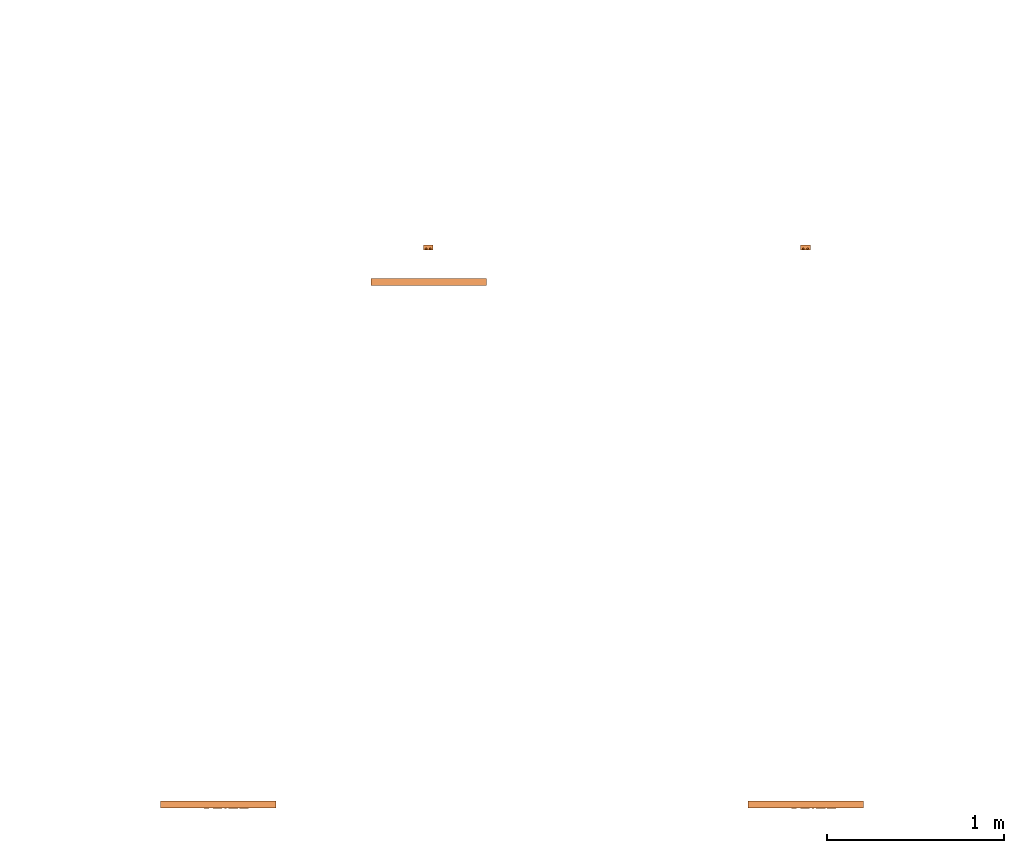
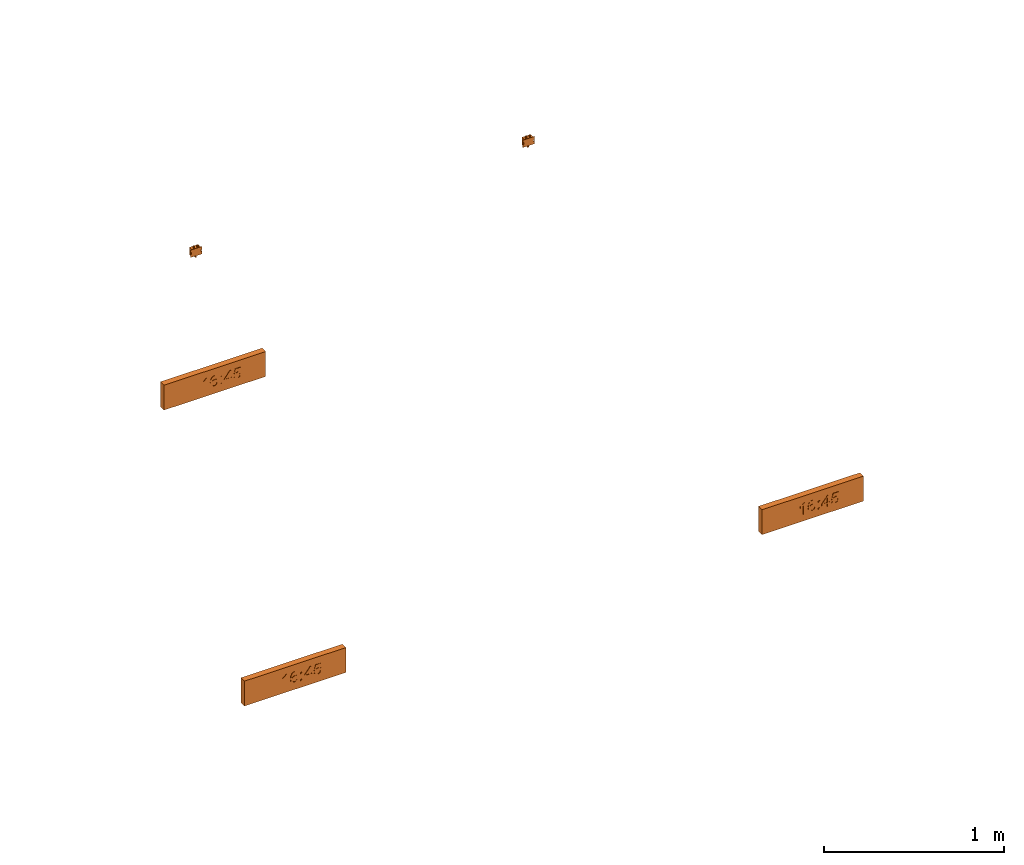
# One storey, part 4 of 6: 5 proxies.
"""IFC2X3 building model written with IfcOpenShell, lengths in millimetres."""

import ifcopenshell
import ifcopenshell.guid

model = None  # the IFC model being written
_history = None  # IfcOwnerHistory: only IFC2X3 demands one
_inside = {}  # id of a spatial element -> (the spatial element, [elements in it])
_under = {}  # id of a project, library or spatial element -> (it, [spatial elements below it])
_declared = {}  # id of a project -> (the project, [libraries it declares])
_typed = {}  # id of a type object -> (the type object, [elements of that type])
_made_of = {}  # id of a material, layer set ... -> (it, [elements and type objects made of it])


def new_model(schema):
    """Start an empty IFC model of exactly this schema.

    Asked for "IFC4X3", IfcOpenShell would pick the latest addendum, in which some entities
    have other attributes; the version numbers below select the first issue.
    IFC2X3 requires an IfcOwnerHistory on every rooted entity: one is made here for all.
    """
    global model, _history
    if schema == "IFC4X3":
        model = ifcopenshell.file(schema_version=(4, 3, 0, 0))
    else:
        model = ifcopenshell.file(schema=schema)
    _inside.clear()
    _under.clear()
    _declared.clear()
    _typed.clear()
    _made_of.clear()
    _history = None
    if model.schema == "IFC2X3":
        org = make("IfcOrganization", Name="unknown")
        user = make(
            "IfcPersonAndOrganization",
            ThePerson=make("IfcPerson", FamilyName="unknown"),
            TheOrganization=org,
        )
        app = make(
            "IfcApplication",
            ApplicationDeveloper=org,
            Version="unknown",
            ApplicationFullName="unknown",
            ApplicationIdentifier="unknown",
        )
        _history = make(
            "IfcOwnerHistory",
            OwningUser=user,
            OwningApplication=app,
            ChangeAction="ADDED",
            CreationDate=0,
        )
    return model


def make(cls, **values):
    """One entity of the class cls with the attributes given. An attribute that is None is left unset."""
    return model.create_entity(
        cls, **{name: value for name, value in values.items() if value is not None}
    )


def entity(cls, *values):
    """Any entity or typed value of the class cls, its attributes in the order of the schema. None: left unset."""
    e = model.create_entity(cls)
    for i, value in enumerate(values):
        if value is not None:
            e[i] = value
    return e


def rooted(cls, **values):
    """An entity with a GlobalId (a new one), such as an element, a storey or a relation."""
    return make(cls, GlobalId=ifcopenshell.guid.new(), OwnerHistory=_history, **values)


def si_unit(unit_type, name, prefix=None):
    """IfcSIUnit, for example si_unit("LENGTHUNIT", "METRE", prefix="MILLI")."""
    return make("IfcSIUnit", UnitType=unit_type, Prefix=prefix, Name=name)


def converted_unit(unit_type, name, factor, base, dimensions=None, offset=None):
    """IfcConversionBasedUnit, such as the inch: factor (a typed value) times the base unit."""
    return make(
        "IfcConversionBasedUnit"
        if offset is None
        else "IfcConversionBasedUnitWithOffset",
        ConversionOffset=offset,
        Dimensions=None
        if dimensions is None
        else entity("IfcDimensionalExponents", *dimensions),
        UnitType=unit_type,
        Name=name,
        ConversionFactor=make(
            "IfcMeasureWithUnit", ValueComponent=factor, UnitComponent=base
        ),
    )


def derived_unit(unit_type, elements):
    """IfcDerivedUnit: a product of units, each with its exponent."""
    return make(
        "IfcDerivedUnit",
        Elements=[
            make("IfcDerivedUnitElement", Unit=unit, Exponent=power)
            for unit, power in elements
        ],
        UnitType=unit_type,
    )


def assignment(units):
    """IfcUnitAssignment: the units of a project."""
    return None if units is None else make("IfcUnitAssignment", Units=units)


def point(xyz):
    """IfcCartesianPoint."""
    return None if xyz is None else make("IfcCartesianPoint", Coordinates=xyz)


def direction(xyz):
    """IfcDirection."""
    return None if xyz is None else make("IfcDirection", DirectionRatios=xyz)


def frame(location, z_axis=None, x_axis=None):
    """IfcAxis2Placement3D, a coordinate frame: its origin and axes. An axis left out is left unset."""
    return make(
        "IfcAxis2Placement3D",
        Location=point(location),
        Axis=direction(z_axis),
        RefDirection=direction(x_axis),
    )


def frame_2d(location, x_axis=None):
    """IfcAxis2Placement2D, a coordinate frame in the plane: its origin and x axis."""
    return make(
        "IfcAxis2Placement2D", Location=point(location), RefDirection=direction(x_axis)
    )


def origin():
    """The frame at (0, 0, 0) with its axes left unset."""
    return frame((0.0, 0.0, 0.0))


def origin_2d_with_axis():
    """The frame at (0, 0) in the plane with the x axis (1, 0) written out."""
    return frame_2d((0.0, 0.0), x_axis=(1.0, 0.0))


def place(relative_to, where):
    """IfcLocalPlacement: puts the frame where relative to a parent placement (None: the world)."""
    return make(
        "IfcLocalPlacement", PlacementRelTo=relative_to, RelativePlacement=where
    )


def context(
    kind, dimensions, precision=None, world=None, true_north=None, identifier=None
):
    """IfcGeometricRepresentationContext, for example the 3D "Model" context."""
    return make(
        "IfcGeometricRepresentationContext",
        ContextIdentifier=identifier,
        ContextType=kind,
        CoordinateSpaceDimension=dimensions,
        Precision=precision,
        WorldCoordinateSystem=world,
        TrueNorth=true_north,
    )


def subcontext(parent, identifier, kind, view, scale=None):
    """IfcGeometricRepresentationSubContext, for example "Body" below "Model"."""
    return make(
        "IfcGeometricRepresentationSubContext",
        ContextIdentifier=identifier,
        ContextType=kind,
        ParentContext=parent,
        TargetScale=scale,
        TargetView=view,
    )


def project(units=None, contexts=None):
    """IfcProject with its units and contexts."""
    return rooted(
        "IfcProject",
        Name="project",
        RepresentationContexts=contexts,
        UnitsInContext=assignment(units),
    )


def spatial(cls, under=None, at=None, **own):
    """A site, building, storey or space (cls), placed at a placement, below another one or the project."""
    s = rooted(cls, ObjectPlacement=at, **own)
    if under is not None:
        _under.setdefault(under.id(), (under, []))[1].append(s)
    return s


def polyline(points):
    """IfcPolyline through the points."""
    return make("IfcPolyline", Points=[point(p) for p in points])


def circle_curve(where, radius):
    """IfcCircle in the frame where."""
    return make("IfcCircle", Position=where, Radius=radius)


def parameter(value):
    """IfcParameterValue: where a trimmed curve begins or ends, as a parameter of its basis curve."""
    return model.create_entity("IfcParameterValue", value)


def trimmed(basis, trim1, trim2, sense, master):
    """IfcTrimmedCurve: the piece of a basis curve between two trims."""
    return make(
        "IfcTrimmedCurve",
        BasisCurve=basis,
        Trim1=trim1,
        Trim2=trim2,
        SenseAgreement=sense,
        MasterRepresentation=master,
    )


def segment(curve, same_sense, transition):
    """IfcCompositeCurveSegment."""
    return make(
        "IfcCompositeCurveSegment",
        Transition=transition,
        SameSense=same_sense,
        ParentCurve=curve,
    )


def composite_curve(segments, self_intersect=None):
    """IfcCompositeCurve: segments joined end to end."""
    return make("IfcCompositeCurve", Segments=segments, SelfIntersect=self_intersect)


def profile(cls, at=None, kind="AREA", **sizes):
    """A parametric profile (cls). Its sizes go by their IFC names, for example OverallWidth=200.0."""
    return make(cls, ProfileType=kind, Position=at, **sizes)


def rectangle(**sizes):
    """IfcRectangleProfileDef."""
    return profile("IfcRectangleProfileDef", **sizes)


def circle(**sizes):
    """IfcCircleProfileDef."""
    return profile("IfcCircleProfileDef", **sizes)


def outline(outer, holes=None, kind="AREA"):
    """IfcArbitraryClosedProfileDef: a profile drawn as a closed curve; with holes, ...WithVoids."""
    if holes is None:
        return make("IfcArbitraryClosedProfileDef", ProfileType=kind, OuterCurve=outer)
    return make(
        "IfcArbitraryProfileDefWithVoids",
        ProfileType=kind,
        OuterCurve=outer,
        InnerCurves=holes,
    )


def extrude(swept, where, along, depth):
    """IfcExtrudedAreaSolid: the profile swept, set in the frame where, extruded along a direction by depth."""
    return make(
        "IfcExtrudedAreaSolid",
        SweptArea=swept,
        Position=where,
        ExtrudedDirection=direction(along),
        Depth=depth,
    )


def shape(context_of_items, identifier, shape_type, items):
    """IfcShapeRepresentation: the items that make up one representation, for example the "Body"."""
    return make(
        "IfcShapeRepresentation",
        ContextOfItems=context_of_items,
        RepresentationIdentifier=identifier,
        RepresentationType=shape_type,
        Items=items,
    )


def source(mapping_origin, context_of_items, identifier, shape_type, items):
    """IfcRepresentationMap: a shape defined once, which mapped items show again and again."""
    return make(
        "IfcRepresentationMap",
        MappingOrigin=mapping_origin,
        MappedRepresentation=shape(context_of_items, identifier, shape_type, items),
    )


def transform(
    local_origin,
    x_axis=None,
    y_axis=None,
    z_axis=None,
    scale=None,
    scale2=None,
    scale3=None,
    uniform=True,
):
    """IfcCartesianTransformationOperator3D, or its non-uniform kind. x_axis, y_axis, z_axis: its Axis1, 2, 3."""
    if uniform:
        return make(
            "IfcCartesianTransformationOperator3D",
            Axis1=direction(x_axis),
            Axis2=direction(y_axis),
            LocalOrigin=point(local_origin),
            Scale=scale,
            Axis3=direction(z_axis),
        )
    return make(
        "IfcCartesianTransformationOperator3DnonUniform",
        Axis1=direction(x_axis),
        Axis2=direction(y_axis),
        LocalOrigin=point(local_origin),
        Scale=scale,
        Axis3=direction(z_axis),
        Scale2=scale2,
        Scale3=scale3,
    )


def mapped(mapping_source, mapping_target):
    """IfcMappedItem: shows the shape of a source again, moved by a transform."""
    return make(
        "IfcMappedItem", MappingSource=mapping_source, MappingTarget=mapping_target
    )


def material(Name=None, Category=None):
    """IfcMaterial."""
    return make("IfcMaterial", Name=Name, Category=Category)


def material_list(materials):
    """IfcMaterialList."""
    return make("IfcMaterialList", Materials=materials)


def made_of(thing, what):
    """Note that an element or type object is made of a material, layer set ...; save() writes the relation."""
    if what is not None:
        _made_of.setdefault(what.id(), (what, []))[1].append(thing)
    return thing


def type_object(cls, material=None, **own):
    """A type object (cls), such as IfcWallType, which elements share."""
    return made_of(rooted(cls, **own), material)


def type_shapes(of_type, sources):
    """Give a type object the sources (RepresentationMaps) that its elements show as mapped items."""
    of_type.RepresentationMaps = sources


def element(
    cls,
    number,
    at=None,
    inside=None,
    cuts=None,
    type_object=None,
    material=None,
    context=None,
    identifier="Body",
    shape_type=None,
    held_by="IfcProductDefinitionShape",
    body=None,
    shapes=None,
    **own,
):
    """One element of the class cls, such as IfcWall. Its Tag is "e" and its number.

    at: its placement. inside: the storey or other place that contains it. cuts: it is an
    opening in that element (IfcRelVoidsElement). A single representation is given by context,
    identifier, shape_type and body (its items); several are given by shapes. held_by: the class
    of the entity that holds the representations. save() writes the other relations.
    """
    e = rooted(cls, Tag="e%d" % number, ObjectPlacement=at, **own)
    if body is not None:
        shapes = [shape(context, identifier, shape_type, body)]
    if shapes is not None:
        e.Representation = make(held_by, Representations=shapes)
    if inside is not None:
        _inside.setdefault(inside.id(), (inside, []))[1].append(e)
    if cuts is not None:
        rooted(
            "IfcRelVoidsElement", RelatingBuildingElement=cuts, RelatedOpeningElement=e
        )
    if type_object is not None:
        _typed.setdefault(type_object.id(), (type_object, []))[1].append(e)
    return made_of(e, material)


def aggregate(whole, parts):
    """IfcRelAggregates: a whole, such as a stair, and the parts it consists of."""
    return rooted("IfcRelAggregates", RelatingObject=whole, RelatedObjects=parts)


def save(model, path):
    """Write the relations noted so far, then the file.

    IfcRelAggregates (storeys below a building ...), IfcRelContainedInSpatialStructure (elements
    in a storey), IfcRelDefinesByType, IfcRelAssociatesMaterial and IfcRelDeclares: one each for
    every whole, place, type object, material and project.
    """
    for whole, parts in _under.values():
        aggregate(whole, parts)
    for where, things in _inside.values():
        rooted(
            "IfcRelContainedInSpatialStructure",
            RelatedElements=things,
            RelatingStructure=where,
        )
    for kind, things in _typed.values():
        rooted("IfcRelDefinesByType", RelatedObjects=things, RelatingType=kind)
    for what, things in _made_of.values():
        rooted("IfcRelAssociatesMaterial", RelatedObjects=things, RelatingMaterial=what)
    for by, libraries in _declared.values():
        rooted("IfcRelDeclares", RelatingContext=by, RelatedDefinitions=libraries)
    model.write(path)


model = new_model("IFC2X3")

# Units and contexts
model_context = context("Model", 3, precision=0.01, world=origin(), true_north=direction((6.12303176911189e-17, 1.0)))
body_context = subcontext(model_context, "Body", "Model", "MODEL_VIEW")
ifc_project = project(units=[si_unit("LENGTHUNIT", "METRE", prefix="MILLI"), si_unit("AREAUNIT", "SQUARE_METRE"), si_unit("VOLUMEUNIT", "CUBIC_METRE"), converted_unit("PLANEANGLEUNIT", "DEGREE", entity("IfcRatioMeasure", 0.0174532925199433), si_unit("PLANEANGLEUNIT", "RADIAN"), dimensions=[0, 0, 0, 0, 0, 0, 0]), si_unit("MASSUNIT", "GRAM", prefix="KILO"), derived_unit("MASSDENSITYUNIT", [(si_unit("MASSUNIT", "GRAM", prefix="KILO"), 1), (si_unit("LENGTHUNIT", "METRE"), -3)]), derived_unit("MOMENTOFINERTIAUNIT", [(si_unit("LENGTHUNIT", "METRE"), 4)]), si_unit("TIMEUNIT", "SECOND"), si_unit("FREQUENCYUNIT", "HERTZ"), si_unit("THERMODYNAMICTEMPERATUREUNIT", "DEGREE_CELSIUS"), derived_unit("THERMALTRANSMITTANCEUNIT", [(si_unit("MASSUNIT", "GRAM", prefix="KILO"), 1), (si_unit("THERMODYNAMICTEMPERATUREUNIT", "KELVIN"), -1), (si_unit("TIMEUNIT", "SECOND"), -3)]), derived_unit("VOLUMETRICFLOWRATEUNIT", [(si_unit("LENGTHUNIT", "METRE"), 3), (si_unit("TIMEUNIT", "SECOND"), -1)]), derived_unit("MASSFLOWRATEUNIT", [(si_unit("MASSUNIT", "GRAM", prefix="KILO"), 1), (si_unit("TIMEUNIT", "SECOND"), -1)]), derived_unit("ROTATIONALFREQUENCYUNIT", [(si_unit("TIMEUNIT", "SECOND"), -1)]), si_unit("ELECTRICCURRENTUNIT", "AMPERE"), si_unit("ELECTRICVOLTAGEUNIT", "VOLT"), si_unit("POWERUNIT", "WATT"), si_unit("FORCEUNIT", "NEWTON", prefix="KILO"), si_unit("ILLUMINANCEUNIT", "LUX"), si_unit("LUMINOUSFLUXUNIT", "LUMEN"), si_unit("LUMINOUSINTENSITYUNIT", "CANDELA"), derived_unit("USERDEFINED", [(si_unit("MASSUNIT", "GRAM", prefix="KILO"), -1), (si_unit("LENGTHUNIT", "METRE"), -2), (si_unit("TIMEUNIT", "SECOND"), 3), (si_unit("LUMINOUSFLUXUNIT", "LUMEN"), 1)]), derived_unit("LINEARVELOCITYUNIT", [(si_unit("LENGTHUNIT", "METRE"), 1), (si_unit("TIMEUNIT", "SECOND"), -1)]), si_unit("PRESSUREUNIT", "PASCAL"), derived_unit("USERDEFINED", [(si_unit("LENGTHUNIT", "METRE"), -2), (si_unit("MASSUNIT", "GRAM", prefix="KILO"), 1), (si_unit("TIMEUNIT", "SECOND"), -2)]), derived_unit("LINEARFORCEUNIT", [(si_unit("MASSUNIT", "GRAM", prefix="KILO"), 1), (si_unit("LENGTHUNIT", "METRE"), 1), (si_unit("TIMEUNIT", "SECOND"), -2), (si_unit("LENGTHUNIT", "METRE"), -1)]), derived_unit("PLANARFORCEUNIT", [(si_unit("MASSUNIT", "GRAM", prefix="KILO"), 1), (si_unit("LENGTHUNIT", "METRE"), 1), (si_unit("TIMEUNIT", "SECOND"), -2), (si_unit("LENGTHUNIT", "METRE"), -2)])], contexts=[model_context])

# Site, building, storey
site_placement = place(None, frame((0.0, -0.00077364408347762, 0.0)))
site = spatial("IfcSite", under=ifc_project, at=site_placement, CompositionType="ELEMENT")
building_placement = place(site_placement, origin())
building = spatial("IfcBuilding", under=site, at=building_placement, CompositionType="ELEMENT")
storey_placement = place(building_placement, frame((0.0, 0.0, 19800.0)))
storey = spatial("IfcBuildingStorey", under=building, at=storey_placement, CompositionType="ELEMENT", Elevation=19800.0)

# Proxies
ifc_material_1 = material()
ifc_material_2 = material()
ifc_material_list_1 = material_list([ifc_material_1, ifc_material_2])
ifc_material_list_2 = material_list([ifc_material_1, ifc_material_1, ifc_material_1, ifc_material_1, ifc_material_1, ifc_material_1, ifc_material_2])
building_element_proxy_type_1 = type_object("IfcBuildingElementProxyType", PredefinedType="NOTDEFINED", material=ifc_material_list_2)
shared_shape_1 = source(origin(), body_context, "Body", "SweptSolid", [
    extrude(outline(polyline([(-49.3297558922559, -13.0650252525253), (28.2460016835017, -13.0650252525253), (28.2460016835017, -6.81502525252525), (17.924031986532, 1.81186868686869), (8.85206228956228, 16.0258838383838), (-0.314604377104382, 16.0258838383838), (4.58122895622896, 5.8175505050505), (11.1247895622896, -3.36805555555555), (-49.3297558922559, -3.36805555555555), (-49.3297558922559, -13.0650252525253)])), frame((-64.5801773123525, 9.80013072699887, 39.0), z_axis=(0.0, 0.0, 1.0), x_axis=(0.0, 1.0, 0.0)), (0.0, 0.0, 1.0), 2.0),
    extrude(outline(polyline([(2.24011853050057, -27.5618774069986), (18.9807108648058, -27.5618774069986), (30.4808593810603, -16.0523867195033), (33.2951509700614, -4.93311916754034), (31.0144130646924, 5.7575762787575), (21.7987736055003, 17.1572643136776), (5.24761200604798, 27.3340921309932), (-11.0974111566595, 32.9532554648861), (-23.9746782077303, 32.7048013849557), (-33.6281248088369, 27.5788768374718), (-40.3016866216521, 18.5656287687041), (-42.7660378318467, 5.67274679265255), (-37.9721755114974, -6.33783567611335), (-27.2455737728681, -14.9533745518323), (-17.5348420919177, -17.6670021030155), (-8.19356542843746, -16.4449721815935), (-0.291454529980238, -11.8654762653203), (5.1017798559014, -4.50670583194971), (7.34785423483786, 6.15330079609256), (4.01114564454941, 17.1916653593814), (18.4548387600492, 7.30997301607691), (23.5935364768699, -2.44380014762508), (21.9745124884661, -11.3576456930974), (14.1729209955885, -18.4151203904576), (5.29132308249511, -18.2779876016039), (2.24011853050057, -27.5618774069986)]), holes=[polyline([(-8.96594443465761, 23.331014608368), (-1.26018519149069, 14.3532201865936), (-2.5541294758174, 1.98565321334379), (-11.3601436525543, -6.99563380914675), (-23.3897211552763, -6.05015679749623), (-32.1796543698203, 2.91675270916293), (-31.2121825444575, 15.1035400981067), (-25.5825280165424, 22.1095150051529), (-17.5185200759943, 24.8943605417974), (-8.96594443465761, 23.331014608368)])]), frame((-2.74431872649391, 3.62832938019752, 39.0), z_axis=(0.0, 0.0, 1.0), x_axis=(-0.427648602040224, 0.903945060926294, 0.0)), (0.0, 0.0, 1.0), 2.0),
    extrude(rectangle(XDim=9.6969696969697, YDim=9.6969696969697, at=origin_2d_with_axis()), frame((40.6060600613849, -34.6811403167722, 39.0)), (0.0, 0.0, 1.0), 2.0),
    extrude(rectangle(XDim=9.6969696969697, YDim=9.6969696969697, at=origin_2d_with_axis()), frame((40.6060600613849, 12.5915869559551, 39.0)), (0.0, 0.0, 1.0), 2.0),
    extrude(outline(polyline([(-0.881542699724549, -28.099173553719), (8.81542699724518, -28.099173553719), (8.81542699724518, -9.91735537190083), (18.5123966942148, -9.91735537190083), (18.5123966942148, -0.220385674931129), (8.81542699724518, -0.220385674931129), (8.81542699724518, 48.2644628099173), (1.54269972451788, 48.2644628099173), (-36.0330578512397, -0.220385674931129), (-36.0330578512397, -9.91735537190083), (-0.881542699724549, -9.91735537190083), (-0.881542699724549, -28.099173553719)]), holes=[polyline([(-0.881542699724549, -0.220385674931129), (-24.1012396694215, -0.220385674931129), (-0.881542699724549, 29.7417355371901), (-0.881542699724549, -0.220385674931129)])]), frame((93.6088148823215, -11.430451611538, 39.0)), (0.0, 0.0, 1.0), 2.0),
    extrude(outline(polyline([(3.28300438653322, -28.2688849771477), (12.486486021848, -28.2688849771477), (20.5381191721727, -25.0278768228724), (26.8189712884816, -18.8467250057334), (30.7101098217491, -10.0262940171423), (31.3981318926443, 1.60805822132837), (26.9015703293825, 11.8381634310008), (20.0564059210334, 18.3764186541994), (11.0756486569987, 22.3371351079238), (1.04176214713842, 23.2585538509025), (-7.93780091536274, 20.406367606958), (-14.9085866775867, 14.4772629545935), (-18.9161412866151, 6.16792647231239), (-17.143675825551, -8.98191514451195), (-36.7240258370804, 0.516426480877832), (-29.0829385906137, 29.2527275669393), (-38.4542673524376, 31.7445980575068), (-48.1102655033866, -4.56930089456074), (-11.6339210401096, -23.0481793347475), (-7.97063445431417, -13.9883343842446), (-10.7994707393594, -7.60185176247611), (-10.2407841657114, 1.05867314396988), (-3.00292415200101, 11.8430863913258), (9.16948621404518, 12.8100644404395), (19.9796079835536, 5.44778336414573), (21.348514929029, -7.49781677359889), (15.5141589936472, -16.4311092462368), (4.60345878187273, -18.5860724040029), (3.28300438653322, -28.2688849771477)])), frame((147.081979974805, -8.48643658300594, 39.0), z_axis=(0.0, 0.0, 1.0), x_axis=(0.256974144339772, -0.966418278563088, 0.0)), (0.0, 0.0, 1.0), 2.0),
    extrude(rectangle(XDim=652.0, YDim=169.000000000001, at=origin_2d_with_axis()), frame((0.0, 0.0, 0.0), z_axis=(0.0, 0.0, 1.0), x_axis=(-1.0, 0.0, 0.0)), (0.0, 0.0, 1.0), 38.9999999999999),
])
type_shapes(building_element_proxy_type_1, [shared_shape_1])
proxy_1_placement = place(storey_placement, frame((50868.8677343591, 4475.0, 2384.50000000001), z_axis=(0.0, -1.0, 0.0), x_axis=(1.0, 0.0, 0.0)))
element("IfcBuildingElementProxy", 1, at=proxy_1_placement, inside=storey, type_object=building_element_proxy_type_1, material=ifc_material_list_1, context=body_context, shape_type="MappedRepresentation", body=[
    mapped(shared_shape_1, transform((0.0, 0.0, 0.0), scale=1.0)),
])
ifc_material_list_3 = material_list([ifc_material_1, ifc_material_2])
proxy_2_placement = place(storey_placement, frame((54191.4407126455, 4475.0, 2384.50000000001), z_axis=(0.0, -1.0, 0.0), x_axis=(1.0, 0.0, 0.0)))
element("IfcBuildingElementProxy", 2, at=proxy_2_placement, inside=storey, type_object=building_element_proxy_type_1, material=ifc_material_list_3, context=body_context, shape_type="MappedRepresentation", body=[
    mapped(shared_shape_1, transform((0.0, 0.0, 0.0), scale=1.0)),
])
ifc_material_list_4 = material_list([ifc_material_1, ifc_material_2])
proxy_3_placement = place(storey_placement, frame((52060.0022397683, 7430.00003712455, 2184.50000000001), z_axis=(0.0, -1.0, 0.0), x_axis=(1.0, 0.0, 0.0)))
element("IfcBuildingElementProxy", 3, at=proxy_3_placement, inside=storey, type_object=building_element_proxy_type_1, material=ifc_material_list_4, context=body_context, shape_type="MappedRepresentation", body=[
    mapped(shared_shape_1, transform((0.0, 0.0, 0.0), scale=1.0)),
])
ifc_material_3 = material()
ifc_material_list_5 = material_list([ifc_material_3, ifc_material_3, ifc_material_3, ifc_material_3, ifc_material_3, ifc_material_3])
building_element_proxy_type_2 = type_object("IfcBuildingElementProxyType", PredefinedType="NOTDEFINED", material=ifc_material_list_5)
shared_shape_2 = source(origin(), body_context, "Body", "SweptSolid", [
    extrude(circle(Radius=5.0, at=frame_2d((-9.06504078924755e-31, 7.40241201668823e-15), x_axis=(1.0, 0.0))), frame((11.9166791548928, 25.0, 8.37499999999769), z_axis=(0.0, 1.0, 0.0), x_axis=(-1.0, 0.0, 0.0)), (0.0, 0.0, 1.0), 13.9999999999909),
    extrude(circle(Radius=5.0, at=frame_2d((-9.06504078924755e-31, 7.40241201668823e-15), x_axis=(1.0, 0.0))), frame((-11.8480864125471, 25.0, 8.37499999999783), z_axis=(0.0, 1.0, 0.0), x_axis=(-1.0, 0.0, 0.0)), (0.0, 0.0, 1.0), 14.0),
    extrude(circle(Radius=5.0, at=frame_2d((2.8490128194778e-30, -2.32647234810202e-14), x_axis=(1.0, 0.0))), frame((0.0269135874528058, -39.0, 8.37499999999739), z_axis=(0.0, 1.0, 0.0), x_axis=(-1.0, 0.0, 0.0)), (0.0, 0.0, 1.0), 13.9999999999909),
    extrude(outline(polyline([(-5.0, -25.0), (5.0, -25.0), (5.0, 25.0), (-5.0, 25.0), (-5.0, -25.0)]), holes=[composite_curve([segment(polyline([(2.00468630441402, 5.0), (2.00468630441402, -5.0)]), True, "CONTINUOUS"), segment(trimmed(circle_curve(frame_2d((0.0, -5.0), x_axis=(-1.0, 0.0)), 2.00468630440306), [parameter(3.56222124323914e-13)], [parameter(180.0)], True, "PARAMETER"), False, "CONTINUOUS"), segment(polyline([(-2.0046863043921, -5.0), (-2.0046863043921, 5.0)]), True, "CONTINUOUS"), segment(trimmed(circle_curve(frame_2d((0.0, 5.0), x_axis=(-1.0, 0.0)), 2.00468630440306), [parameter(180.0)], [parameter(5.08888749034163e-13)], True, "PARAMETER"), False, "CONTINUOUS")], self_intersect=False)]), frame((32.5000000000068, 0.0, 0.0), z_axis=(0.0, 0.0, 1.0), x_axis=(-1.0, 0.0, 0.0)), (0.0, 0.0, 1.0), 2.0),
    extrude(outline(polyline([(-5.0, -25.0), (5.0, -25.0), (5.0, 25.0), (-5.0, 25.0), (-5.0, -25.0)]), holes=[composite_curve([segment(polyline([(-2.00468630441444, -5.0), (-2.00468630441444, 5.0)]), True, "CONTINUOUS"), segment(trimmed(circle_curve(frame_2d((0.0, 5.0), x_axis=(-1.0, 0.0)), 2.00468630440306), [parameter(180.0)], [parameter(5.08888749034163e-13)], True, "PARAMETER"), False, "CONTINUOUS"), segment(polyline([(2.00468630439168, 5.0), (2.00468630439169, -5.0)]), True, "CONTINUOUS"), segment(trimmed(circle_curve(frame_2d((0.0, -5.0), x_axis=(-1.0, 0.0)), 2.00468630440306), [parameter(4.57999874130747e-13)], [parameter(180.0)], True, "PARAMETER"), False, "CONTINUOUS")], self_intersect=False)]), frame((-32.4999999999936, 0.0, 0.0), z_axis=(0.0, 0.0, 1.0), x_axis=(-1.0, 0.0, 0.0)), (0.0, 0.0, 1.0), 2.0),
    extrude(rectangle(XDim=55.0, YDim=49.9999999999997, at=frame_2d((0.0, 1.77635683940025e-15), x_axis=(1.0, 0.0))), frame((0.0, 0.0, 0.0), z_axis=(0.0, 0.0, 1.0), x_axis=(-1.0, 0.0, 0.0)), (0.0, 0.0, 1.0), 28.0),
])
type_shapes(building_element_proxy_type_2, [shared_shape_2])
proxy_4_placement = place(storey_placement, frame((54189.585659984, 7590.0, 2939.50000000001), z_axis=(0.0, 1.0, 0.0), x_axis=(-1.0, 0.0, 0.0)))
element("IfcBuildingElementProxy", 4, at=proxy_4_placement, inside=storey, type_object=building_element_proxy_type_2, material=ifc_material_3, context=body_context, shape_type="MappedRepresentation", body=[
    mapped(shared_shape_2, transform((0.0, 0.0, 0.0), scale=1.0)),
])
ifc_material_list_6 = material_list([ifc_material_3, ifc_material_3, ifc_material_3, ifc_material_3, ifc_material_3, ifc_material_3])
ifc_material_list_7 = material_list([ifc_material_3, ifc_material_3, ifc_material_3, ifc_material_3, ifc_material_3, ifc_material_3])
building_element_proxy_type_3 = type_object("IfcBuildingElementProxyType", PredefinedType="NOTDEFINED", material=ifc_material_list_7)
shared_shape_3 = source(origin(), body_context, "Body", "SweptSolid", [
    extrude(circle(Radius=5.0, at=frame_2d((-9.06504078924755e-31, 7.40241201668823e-15), x_axis=(1.0, 0.0))), frame((11.9166791548928, 25.0, 8.37499999999769), z_axis=(0.0, 1.0, 0.0), x_axis=(-1.0, 0.0, 0.0)), (0.0, 0.0, 1.0), 13.9999999999909),
    extrude(circle(Radius=5.0, at=frame_2d((-9.06504078924755e-31, 7.40241201668823e-15), x_axis=(1.0, 0.0))), frame((-11.8480864125471, 25.0, 8.37499999999783), z_axis=(0.0, 1.0, 0.0), x_axis=(-1.0, 0.0, 0.0)), (0.0, 0.0, 1.0), 14.0),
    extrude(circle(Radius=5.0, at=frame_2d((2.8490128194778e-30, -2.32647234810202e-14), x_axis=(1.0, 0.0))), frame((0.0269135874528058, -39.0, 8.37499999999739), z_axis=(0.0, 1.0, 0.0), x_axis=(-1.0, 0.0, 0.0)), (0.0, 0.0, 1.0), 13.9999999999909),
    extrude(outline(polyline([(-5.0, -25.0), (5.0, -25.0), (5.0, 25.0), (-5.0, 25.0), (-5.0, -25.0)]), holes=[composite_curve([segment(polyline([(2.00468630441402, 5.0), (2.00468630441402, -5.0)]), True, "CONTINUOUS"), segment(trimmed(circle_curve(frame_2d((0.0, -5.0), x_axis=(-1.0, 0.0)), 2.00468630440306), [parameter(3.56222124323914e-13)], [parameter(180.0)], True, "PARAMETER"), False, "CONTINUOUS"), segment(polyline([(-2.0046863043921, -5.0), (-2.0046863043921, 5.0)]), True, "CONTINUOUS"), segment(trimmed(circle_curve(frame_2d((0.0, 5.0), x_axis=(-1.0, 0.0)), 2.00468630440306), [parameter(180.0)], [parameter(5.08888749034163e-13)], True, "PARAMETER"), False, "CONTINUOUS")], self_intersect=False)]), frame((32.5000000000068, 0.0, 0.0), z_axis=(0.0, 0.0, 1.0), x_axis=(-1.0, 0.0, 0.0)), (0.0, 0.0, 1.0), 2.0),
    extrude(outline(polyline([(-5.0, -25.0), (5.0, -25.0), (5.0, 25.0), (-5.0, 25.0), (-5.0, -25.0)]), holes=[composite_curve([segment(polyline([(-2.00468630441444, -5.0), (-2.00468630441444, 5.0)]), True, "CONTINUOUS"), segment(trimmed(circle_curve(frame_2d((0.0, 5.0), x_axis=(-1.0, 0.0)), 2.00468630440306), [parameter(180.0)], [parameter(5.08888749034163e-13)], True, "PARAMETER"), False, "CONTINUOUS"), segment(polyline([(2.00468630439168, 5.0), (2.00468630439169, -5.0)]), True, "CONTINUOUS"), segment(trimmed(circle_curve(frame_2d((0.0, -5.0), x_axis=(-1.0, 0.0)), 2.00468630440306), [parameter(4.57999874130747e-13)], [parameter(180.0)], True, "PARAMETER"), False, "CONTINUOUS")], self_intersect=False)]), frame((-32.4999999999936, 0.0, 0.0), z_axis=(0.0, 0.0, 1.0), x_axis=(-1.0, 0.0, 0.0)), (0.0, 0.0, 1.0), 2.0),
    extrude(rectangle(XDim=55.0, YDim=49.9999999999997, at=frame_2d((0.0, 1.77635683940025e-15), x_axis=(1.0, 0.0))), frame((0.0, 0.0, 0.0), z_axis=(0.0, 0.0, 1.0), x_axis=(-1.0, 0.0, 0.0)), (0.0, 0.0, 1.0), 28.0),
])
type_shapes(building_element_proxy_type_3, [shared_shape_3])
proxy_5_placement = place(storey_placement, frame((52056.2787228555, 7590.00003712455, 2939.50000000001), z_axis=(0.0, 1.0, 0.0), x_axis=(-1.0, 0.0, 0.0)))
element("IfcBuildingElementProxy", 5, at=proxy_5_placement, inside=storey, type_object=building_element_proxy_type_3, material=ifc_material_list_6, context=body_context, shape_type="MappedRepresentation", body=[
    mapped(shared_shape_3, transform((0.0, 0.0, 0.0), scale=1.0)),
])

save(model, "model.ifc")
